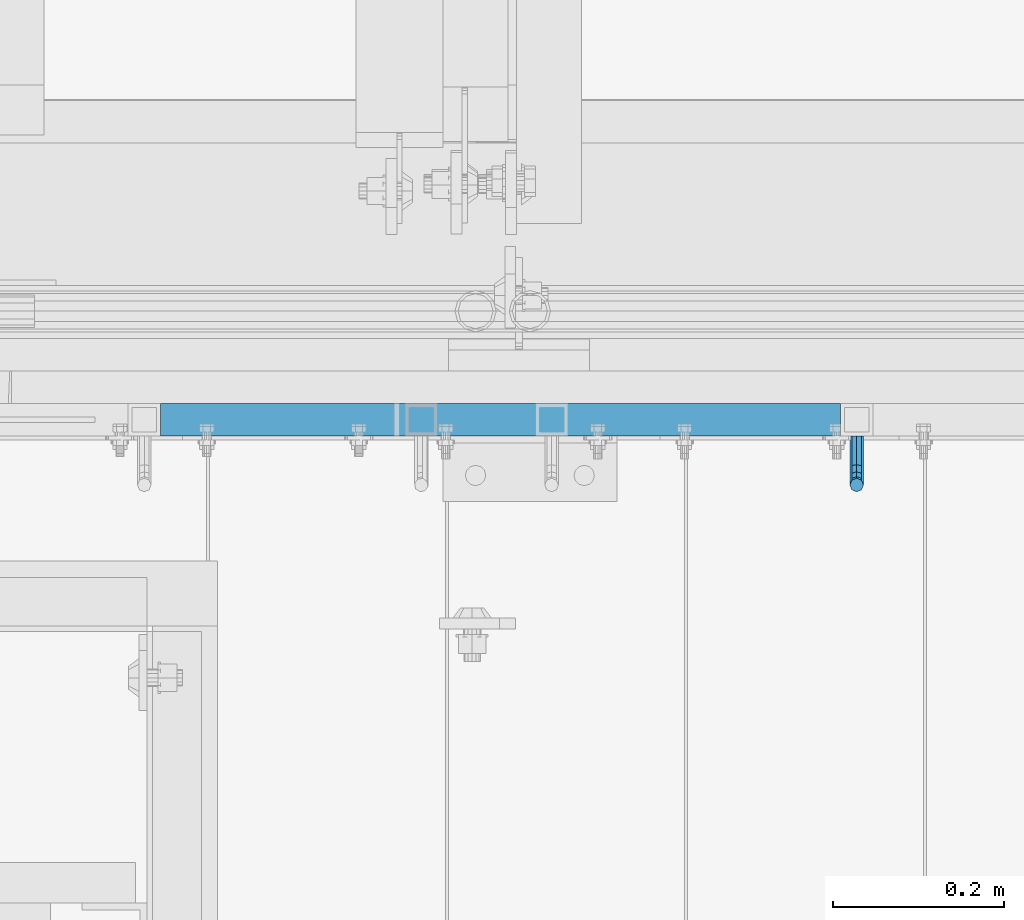
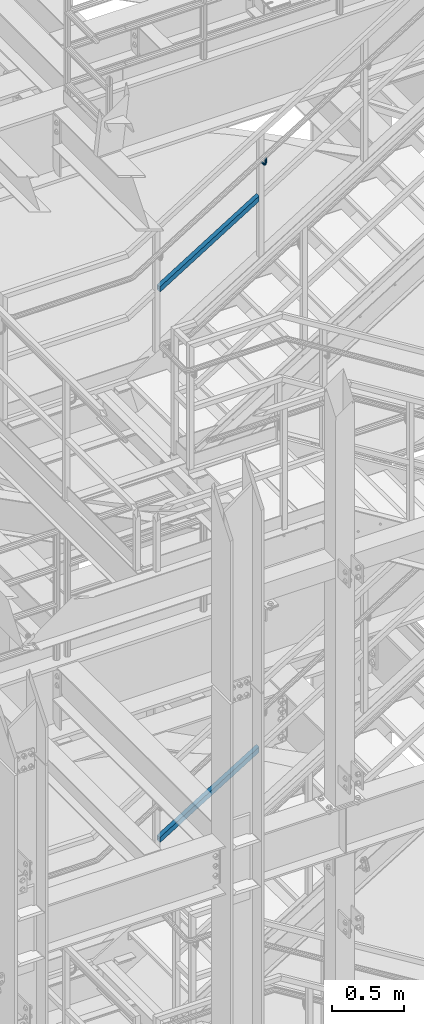
# One storey, part 1177 of 1876: 2 members, 1 beam, 2 elements without a shape of their own.
"""IFC2X3 building model written with IfcOpenShell, lengths in millimetres."""

from ifc_helpers import new_model, si_unit, frame, origin_with_axes, place, context, subcontext, project, spatial, faceted_brep, material, type_object, element, aggregate, save


model = new_model("IFC2X3")

# Units and contexts
model_context = context("Model", 3, precision=1e-05, world=origin_with_axes())
body_context = subcontext(model_context, "Body", "Model", "MODEL_VIEW")
ifc_project = project(units=[si_unit("LENGTHUNIT", "METRE", prefix="MILLI"), si_unit("AREAUNIT", "SQUARE_METRE"), si_unit("VOLUMEUNIT", "CUBIC_METRE"), si_unit("MASSUNIT", "GRAM", prefix="KILO"), si_unit("TIMEUNIT", "SECOND"), si_unit("PLANEANGLEUNIT", "RADIAN"), si_unit("SOLIDANGLEUNIT", "STERADIAN"), si_unit("THERMODYNAMICTEMPERATUREUNIT", "DEGREE_CELSIUS"), si_unit("LUMINOUSINTENSITYUNIT", "LUMEN")], contexts=[model_context])

# Site, building, storey
site_placement = place(None, origin_with_axes())
site = spatial("IfcSite", under=ifc_project, at=site_placement, CompositionType="ELEMENT")
building_placement = place(site_placement, origin_with_axes())
building = spatial("IfcBuilding", under=site, at=building_placement, Name="Undefined", CompositionType="ELEMENT")
storey_placement = place(building_placement, origin_with_axes())
storey = spatial("IfcBuildingStorey", under=building, at=storey_placement, Name="Undefined", CompositionType="ELEMENT", Elevation=0.0)

# Assembly, beam
assembly_1_placement = place(storey_placement, origin_with_axes())
assembly_1 = element("IfcElementAssembly", 1, at=assembly_1_placement, inside=storey, Name="RAIL", AssemblyPlace="NOTDEFINED", PredefinedType="RIGID_FRAME")
ifc_material_1 = material(Name="STEEL/A36")
beam_type = type_object("IfcBeamType", PredefinedType="NOTDEFINED")
beam_placement = place(assembly_1_placement, frame((3252.25833234056, -4800.60000114554, 17056.4472239866), z_axis=(-1.0, 0.0, 0.0), x_axis=(0.0, -1.0, 0.0)))
beam = element("IfcBeam", 2, at=beam_placement, type_object=beam_type, material=ifc_material_1, Name="BRACKET", context=body_context, shape_type="Brep", body=[
    faceted_brep([(0.0, -5.61266007566822, 5.61266007566883), (0.0, 0.0, 7.9375), (0.0, 5.61266007566822, 5.61266007566883), (0.0, 7.9375, 0.0), (0.0, 5.61266007566822, -5.61266007566883), (0.0, 0.0, -7.9375), (0.0, -5.61266007566822, -5.61266007566883), (0.0, -7.9375, 0.0), (23.8125, -5.61266007566883, -5.61266007566792), (23.8125, -7.9375, 0.0), (23.8125, -5.61266007566883, 5.61266007566792), (23.8125, 0.0, 7.9375), (23.8125, 5.61266007566883, 5.61266007566792), (23.8125, 7.9375, 0.0), (23.8125, 5.61266007566883, -5.61266007566792), (23.8125, 0.0, -7.9375), (36.5702095103998, 2.53766620105671, -7.9375), (38.7180815328556, -2.64775556579843, -5.61266007566792), (39.6077592547981, -4.79562758825341, 0.0), (38.7180815328556, -2.64775556579843, 5.61266007566792), (36.5702095103998, 2.53766620105671, 7.9375), (34.4223374879448, 7.72308796790821, 5.61266007566792), (33.5326597660023, 9.87095999036319, 0.0), (34.4223374879448, 7.72308796790821, -5.61266007566792), (43.4169233967659, 13.733078129113, -5.61266007566792), (47.3856733967659, 9.76432812911298, -7.9375), (41.773013321098, 15.3769882047818, 0.0), (43.4169233967659, 13.733078129113, 5.61266007566792), (47.3856733967659, 9.76432812911298, 7.9375), (51.3544233967659, 5.79557812911298, 5.61266007566792), (52.9983334724348, 4.15166805344415, 0.0), (51.3544233967659, 5.79557812911298, -5.61266007566792), (54.6123353248231, 20.5797920154801, -7.9375), (59.7977570916764, 18.4319199930251, -5.61266007566792), (49.4269135579698, 22.727664037935, -5.61266007566792), (47.2790415355148, 23.6173417598766, 0.0), (49.4269135579698, 22.727664037935, 5.61266007566792), (54.6123353248231, 20.5797920154801, 7.9375), (59.7977570916764, 18.4319199930251, 5.61266007566792), (61.9456291141314, 17.5422422710835, 0.0), (62.7626616015468, 33.3375015258789, -5.61266007566792), (65.0875015258789, 33.3375015258789, 0.0), (57.1500015258789, 33.3375015258789, -7.9375), (51.5373414502101, 33.3375015258789, -5.61266007566792), (49.2125015258789, 33.3375015258789, 0.0), (51.5373414502101, 33.3375015258789, 5.61266007566792), (57.1500015258789, 33.3375015258789, 7.9375), (62.7626616015468, 33.3375015258789, 5.61266007566792), (65.0875015258789, 66.4903820289292, 0.0), (62.7626616015468, 63.0131702244908, 5.61266007566837), (57.1500015258789, 61.5728619358488, 7.9375), (51.537341450211, 63.0131702244908, 5.61266007566837), (49.2125015258789, 66.4903820289292, 0.0), (51.537341450211, 69.9675938333676, -5.61266007566837), (57.1500015258789, 71.4079021220132, -7.9375), (62.7626616015468, 69.9675938333676, -5.61266007566837)], [[[0, 1, 2, 3, 4, 5, 6, 7]], [[7, 6, 8, 9]], [[0, 7, 9, 10]], [[1, 0, 10, 11]], [[2, 1, 11, 12]], [[3, 2, 12, 13]], [[4, 3, 13, 14]], [[5, 4, 14, 15]], [[6, 5, 15, 8]], [[8, 15, 16, 17]], [[9, 8, 17, 18]], [[10, 9, 18, 19]], [[11, 10, 19, 20]], [[12, 11, 20, 21]], [[13, 12, 21, 22]], [[14, 13, 22, 23]], [[15, 14, 23, 16]], [[23, 24, 25, 16]], [[22, 26, 24, 23]], [[21, 27, 26, 22]], [[20, 28, 27, 21]], [[19, 29, 28, 20]], [[18, 30, 29, 19]], [[17, 31, 30, 18]], [[16, 25, 31, 17]], [[25, 32, 33, 31]], [[24, 34, 32, 25]], [[26, 35, 34, 24]], [[27, 36, 35, 26]], [[28, 37, 36, 27]], [[29, 38, 37, 28]], [[30, 39, 38, 29]], [[31, 33, 39, 30]], [[33, 40, 41, 39]], [[32, 42, 40, 33]], [[34, 43, 42, 32]], [[35, 44, 43, 34]], [[36, 45, 44, 35]], [[37, 46, 45, 36]], [[38, 47, 46, 37]], [[39, 41, 47, 38]], [[47, 41, 48, 49]], [[46, 47, 49, 50]], [[45, 46, 50, 51]], [[44, 45, 51, 52]], [[43, 44, 52, 53]], [[42, 43, 53, 54]], [[40, 42, 54, 55]], [[41, 40, 55, 48]], [[54, 53, 52, 51, 50, 49, 48, 55]]]),
])

# Assembly, member
assembly_2_placement = place(storey_placement, origin_with_axes())
assembly_2 = element("IfcElementAssembly", 3, at=assembly_2_placement, inside=storey, Name="RAIL", AssemblyPlace="NOTDEFINED", PredefinedType="RIGID_FRAME")
ifc_material_2 = material()
member_type = type_object("IfcMemberType", Name="HSS1-1/2X1-1/2X1/8", PredefinedType="NOTDEFINED")
member_1_placement = place(assembly_2_placement, frame((2419.35000034927, -4781.55000114554, 11590.8281812857), z_axis=(-0.523953411146183, 0.0, 0.851746924237639), x_axis=(0.851746924237639, 0.0, 0.523953411146184)))
member_1 = element("IfcMember", 4, at=member_1_placement, type_object=member_type, material=ifc_material_2, Name="RAIL", ObjectType="HSS1-1/2X1-1/2X1/8", context=body_context, shape_type="Brep", body=[
    faceted_brep([(967.235246310049, -19.0499992349996, 19.0499992350105), (943.797974516105, -19.0499992349996, -19.0499992349924), (943.797974516105, 19.0499992349996, -19.0499992349924), (967.235246310049, 19.0499992349996, 19.0499992350105), (965.282140278314, -15.8749992829999, 15.8749992830126), (965.282140278314, 15.8749992829999, 15.8749992830126), (945.751080547838, 15.8749992829999, -15.8749992829926), (945.751080547838, -15.8749992829999, -15.8749992829926), (34.0844334038557, 19.0499992349996, 19.0499992349978), (34.0844334038557, -19.0499992349996, 19.0499992349978), (10.6471616099025, -19.0499992349996, -19.0499992350033), (10.6471616099025, 19.0499992349996, -19.0499992350033), (32.1313273721225, 15.8749992829999, 15.874999282998), (32.1313273721225, -15.8749992829999, 15.874999282998), (12.6002676416374, -15.8749992829999, -15.8749992830035), (12.6002676416374, 15.8749992829999, -15.8749992830035)], [[[0, 1, 2, 3], [4, 5, 6, 7]], [[0, 3, 8, 9]], [[2, 1, 10, 11]], [[1, 0, 9, 10]], [[3, 2, 11, 8]], [[10, 9, 8, 11], [12, 13, 14, 15]], [[4, 7, 14, 13]], [[7, 6, 15, 14]], [[6, 5, 12, 15]], [[5, 4, 13, 12]]]),
])
aggregate(assembly_2, [member_1])

# Member
member_2_placement = place(assembly_1_placement, frame((2419.34999989535, -4781.55000114554, 16248.4718492977), z_axis=(-0.526627379729772, 0.0, 0.850096231563789), x_axis=(0.850096231563789, 0.0, 0.526627379729772)))
member_2 = element("IfcMember", 5, at=member_2_placement, type_object=member_type, material=ifc_material_2, Name="RAIL", ObjectType="HSS1-1/2X1-1/2X1/8", context=body_context, shape_type="Brep", body=[
    faceted_brep([(969.17331595645, -19.0499992349996, 19.0499992348905), (945.570691198265, -19.0499992349996, -19.049999235076), (945.570691198265, 19.0499992349996, -19.049999235076), (969.17331595645, 19.0499992349996, 19.0499992348905), (967.206430510685, -15.8749992829999, 15.8749992828944), (967.206430510685, 15.8749992829999, 15.8749992828944), (947.53757664403, 15.8749992829999, -15.8749992830781), (947.53757664403, -15.8749992829999, -15.8749992830781), (34.210539160511, 19.0499992349996, 19.0499992350342), (34.210539160511, -19.0499992349996, 19.0499992350342), (10.6079144021951, -19.0499992349996, -19.0499992349669), (10.6079144021951, 19.0499992349996, -19.0499992349669), (32.243653714735, 15.8749992829999, 15.8749992830344), (32.243653714735, -15.8749992829999, 15.8749992830344), (12.574799847971, -15.8749992829999, -15.8749992829671), (12.574799847971, 15.8749992829999, -15.8749992829671)], [[[0, 1, 2, 3], [4, 5, 6, 7]], [[8, 9, 0, 3]], [[10, 11, 2, 1]], [[9, 10, 1, 0]], [[11, 8, 3, 2]], [[10, 9, 8, 11], [12, 13, 14, 15]], [[14, 13, 4, 7]], [[15, 14, 7, 6]], [[12, 15, 6, 5]], [[13, 12, 5, 4]]]),
])

aggregate(assembly_1, [beam, member_2])

save(model, "model.ifc")
